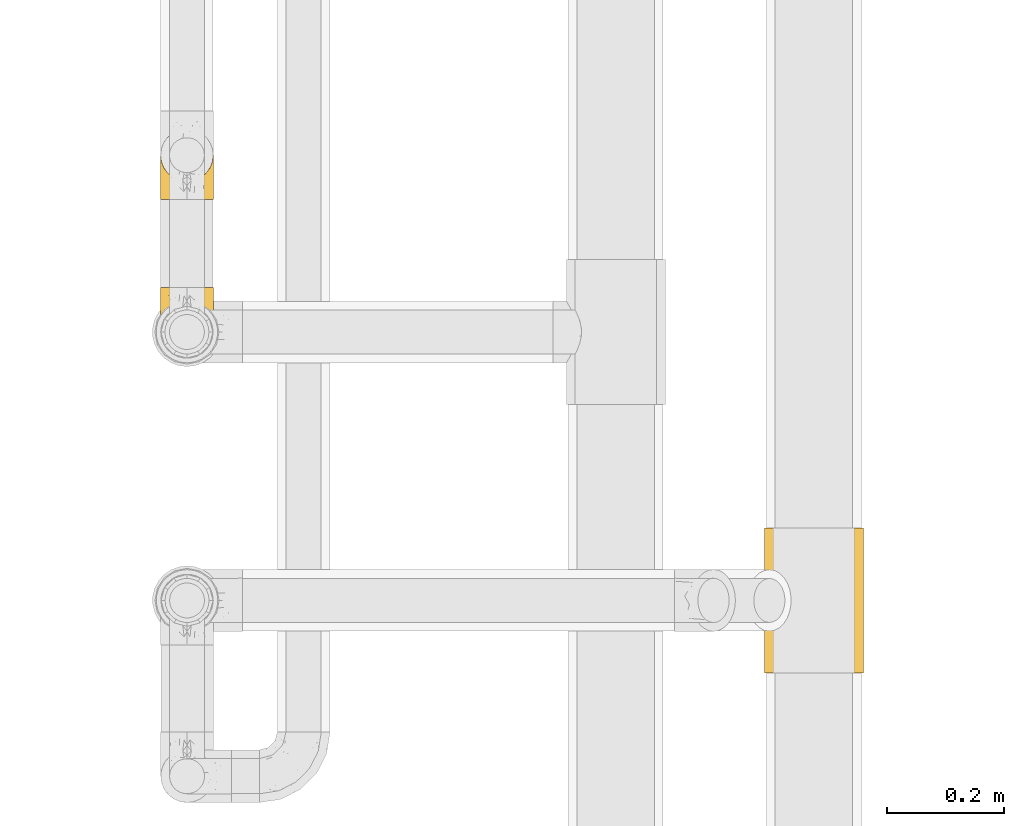
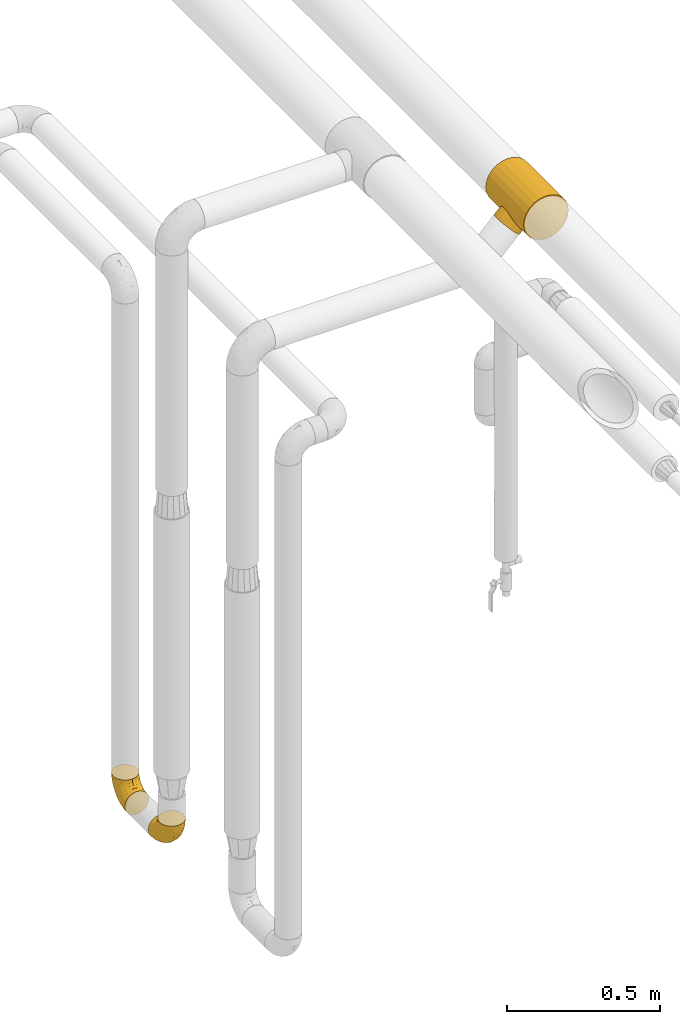
# One storey, part 112 of 827: 3 coverings.
"""IFC2X3 building model written with IfcOpenShell, lengths in millimetres."""

from ifc_helpers import new_model, entity, si_unit, converted_unit, derived_unit, direction, frame, origin, place, context, subcontext, project, spatial, faceted_brep, element, save


model = new_model("IFC2X3")

# Units and contexts
model_context = context("Model", 3, precision=0.01, world=origin(), true_north=direction((6.12303176911189e-17, 1.0)))
body_context = subcontext(model_context, "Body", "Model", "MODEL_VIEW")
ifc_project = project(units=[si_unit("LENGTHUNIT", "METRE", prefix="MILLI"), si_unit("AREAUNIT", "SQUARE_METRE"), si_unit("VOLUMEUNIT", "CUBIC_METRE"), converted_unit("PLANEANGLEUNIT", "DEGREE", entity("IfcRatioMeasure", 0.0174532925199433), si_unit("PLANEANGLEUNIT", "RADIAN"), dimensions=[0, 0, 0, 0, 0, 0, 0]), si_unit("MASSUNIT", "GRAM", prefix="KILO"), derived_unit("MASSDENSITYUNIT", [(si_unit("MASSUNIT", "GRAM", prefix="KILO"), 1), (si_unit("LENGTHUNIT", "METRE"), -3)]), derived_unit("MOMENTOFINERTIAUNIT", [(si_unit("LENGTHUNIT", "METRE"), 4)]), si_unit("TIMEUNIT", "SECOND"), si_unit("FREQUENCYUNIT", "HERTZ"), si_unit("THERMODYNAMICTEMPERATUREUNIT", "DEGREE_CELSIUS"), derived_unit("THERMALTRANSMITTANCEUNIT", [(si_unit("MASSUNIT", "GRAM", prefix="KILO"), 1), (si_unit("THERMODYNAMICTEMPERATUREUNIT", "KELVIN"), -1), (si_unit("TIMEUNIT", "SECOND"), -3)]), derived_unit("VOLUMETRICFLOWRATEUNIT", [(si_unit("LENGTHUNIT", "METRE"), 3), (si_unit("TIMEUNIT", "SECOND"), -1)]), derived_unit("MASSFLOWRATEUNIT", [(si_unit("MASSUNIT", "GRAM", prefix="KILO"), 1), (si_unit("TIMEUNIT", "SECOND"), -1)]), derived_unit("ROTATIONALFREQUENCYUNIT", [(si_unit("TIMEUNIT", "SECOND"), -1)]), si_unit("ELECTRICCURRENTUNIT", "AMPERE"), si_unit("ELECTRICVOLTAGEUNIT", "VOLT"), si_unit("POWERUNIT", "WATT"), si_unit("FORCEUNIT", "NEWTON", prefix="KILO"), si_unit("ILLUMINANCEUNIT", "LUX"), si_unit("LUMINOUSFLUXUNIT", "LUMEN"), si_unit("LUMINOUSINTENSITYUNIT", "CANDELA"), derived_unit("USERDEFINED", [(si_unit("MASSUNIT", "GRAM", prefix="KILO"), -1), (si_unit("LENGTHUNIT", "METRE"), -2), (si_unit("TIMEUNIT", "SECOND"), 3), (si_unit("LUMINOUSFLUXUNIT", "LUMEN"), 1)]), derived_unit("LINEARVELOCITYUNIT", [(si_unit("LENGTHUNIT", "METRE"), 1), (si_unit("TIMEUNIT", "SECOND"), -1)]), si_unit("PRESSUREUNIT", "PASCAL"), derived_unit("USERDEFINED", [(si_unit("LENGTHUNIT", "METRE"), -2), (si_unit("MASSUNIT", "GRAM", prefix="KILO"), 1), (si_unit("TIMEUNIT", "SECOND"), -2)]), derived_unit("LINEARFORCEUNIT", [(si_unit("MASSUNIT", "GRAM", prefix="KILO"), 1), (si_unit("LENGTHUNIT", "METRE"), 1), (si_unit("TIMEUNIT", "SECOND"), -2), (si_unit("LENGTHUNIT", "METRE"), -1)]), derived_unit("PLANARFORCEUNIT", [(si_unit("MASSUNIT", "GRAM", prefix="KILO"), 1), (si_unit("LENGTHUNIT", "METRE"), 1), (si_unit("TIMEUNIT", "SECOND"), -2), (si_unit("LENGTHUNIT", "METRE"), -2)])], contexts=[model_context])

# Site, building, storey
site_placement = place(None, origin())
site = spatial("IfcSite", under=ifc_project, at=site_placement, CompositionType="ELEMENT")
building_placement = place(site_placement, origin())
building = spatial("IfcBuilding", under=site, at=building_placement, CompositionType="ELEMENT")
storey_placement = place(building_placement, frame((0.0, 0.0, 28200.0)))
storey = spatial("IfcBuildingStorey", under=building, at=storey_placement, Name="08", CompositionType="ELEMENT", Elevation=28200.0)

# Coverings
covering_1_placement = place(storey_placement, frame((22059.28, 10675.65, 2684.46)))
element("IfcCovering", 1, at=covering_1_placement, inside=storey, Name=":ADSK_", ObjectType=":ADSK_", PredefinedType="INSULATION", context=body_context, shape_type="Brep", body=[
    faceted_brep([(197.43, 0.0, 137.44), (188.96, 0.0, 157.9), (175.47, 0.0, 175.47), (157.9, 0.0, 188.96), (137.44, 0.0, 197.43), (115.47, 0.0, 200.32), (93.51, 0.0, 197.43), (73.05, 0.0, 188.96), (55.48, 0.0, 175.47), (41.99, 0.0, 157.9), (33.52, 0.0, 137.44), (30.62, 0.0, 115.47), (33.52, 0.0, 93.51), (37.75, 0.0, 83.28), (41.99, 0.0, 73.05), (48.73, 0.0, 64.26), (55.48, 0.0, 55.48), (64.26, 0.0, 48.73), (73.05, 0.0, 41.99), (83.28, 0.0, 37.75), (93.51, 0.0, 33.52), (115.47, 0.0, 30.62), (137.44, 0.0, 33.52), (157.9, 0.0, 41.99), (175.47, 0.0, 55.48), (188.96, 0.0, 73.05), (197.43, 0.0, 93.51), (200.32, 0.0, 115.47), (55.48, 248.0, 175.47), (73.05, 248.0, 188.96), (93.51, 248.0, 197.43), (115.47, 248.0, 200.32), (137.44, 248.0, 197.43), (157.9, 248.0, 188.96), (175.47, 248.0, 175.47), (188.96, 248.0, 157.9), (197.43, 248.0, 137.44), (200.32, 248.0, 115.47), (197.43, 248.0, 93.51), (188.96, 248.0, 73.05), (175.47, 248.0, 55.48), (157.9, 248.0, 41.99), (137.44, 248.0, 33.52), (115.47, 248.0, 30.62), (93.51, 248.0, 33.52), (83.28, 248.0, 37.75), (73.05, 248.0, 41.99), (64.26, 248.0, 48.73), (55.48, 248.0, 55.48), (48.73, 248.0, 64.26), (41.99, 248.0, 73.05), (37.75, 248.0, 83.28), (33.52, 248.0, 93.51), (30.62, 248.0, 115.47), (33.52, 248.0, 137.44), (41.99, 248.0, 157.9), (32.13, 147.29, 99.54), (41.25, 76.39, 74.36), (36.75, 82.7, 83.83), (31.35, 136.08, 104.4), (47.52, 175.65, 64.66), (31.14, 124.0, 106.16), (31.35, 111.92, 104.4), (55.48, 70.95, 55.48), (47.52, 72.35, 64.66), (32.13, 100.71, 99.54), (36.75, 165.3, 83.83), (33.81, 157.11, 92.43), (41.25, 171.61, 74.36), (55.48, 177.05, 55.48), (33.81, 90.89, 92.43), (64.66, 175.65, 47.52), (74.36, 171.61, 41.25), (92.43, 157.11, 33.81), (83.83, 165.3, 36.75), (64.66, 72.35, 47.52), (74.36, 76.39, 41.25), (83.83, 82.7, 36.75), (92.43, 90.89, 33.81), (99.54, 147.29, 32.13), (104.4, 136.08, 31.35), (106.16, 124.0, 31.14), (99.54, 100.71, 32.13), (104.4, 111.92, 31.35), (1.6, 124.0, 76.62), (2.87, 137.73, 75.34), (6.62, 150.52, 71.59), (12.58, 161.51, 65.63), (20.35, 169.94, 57.86), (29.4, 175.24, 48.82), (39.11, 177.05, 39.11), (48.82, 175.24, 29.4), (57.86, 169.94, 20.35), (65.63, 161.51, 12.58), (71.59, 150.52, 6.62), (75.34, 137.73, 2.87), (76.62, 124.0, 1.6), (75.34, 110.27, 2.87), (71.59, 97.47, 6.62), (65.63, 86.49, 12.58), (57.86, 78.06, 20.35), (48.82, 72.76, 29.4), (39.11, 70.95, 39.11), (29.4, 72.76, 48.82), (20.35, 78.06, 57.86), (12.58, 86.49, 65.63), (6.62, 97.47, 71.59), (2.87, 110.27, 75.34)], [[[0, 1, 2, 3, 4, 5, 6, 7, 8, 9, 10, 11, 12, 13, 14, 15, 16, 17, 18, 19, 20, 21, 22, 23, 24, 25, 26, 27]], [[28, 29, 30, 31, 32, 33, 34, 35, 36, 37, 38, 39, 40, 41, 42, 43, 44, 45, 46, 47, 48, 49, 50, 51, 52, 53, 54, 55]], [[3, 33, 32, 4]], [[4, 32, 31, 5]], [[34, 33, 3, 2]], [[6, 30, 29, 7]], [[7, 29, 28, 8]], [[5, 31, 30, 6]], [[55, 9, 8, 28]], [[54, 10, 9, 55]], [[53, 52, 56]], [[57, 13, 58]], [[56, 59, 53]], [[60, 50, 49]], [[54, 53, 11, 10]], [[53, 59, 61]], [[61, 62, 11]], [[63, 15, 64]], [[11, 65, 12]], [[65, 11, 62]], [[66, 52, 51]], [[11, 53, 61]], [[56, 52, 67]], [[67, 52, 66]], [[66, 51, 68]], [[48, 69, 49]], [[63, 16, 15]], [[60, 49, 69]], [[50, 60, 68]], [[50, 68, 51]], [[70, 58, 12]], [[13, 57, 14]], [[58, 13, 12]], [[12, 65, 70]], [[15, 14, 64]], [[64, 14, 57]], [[48, 47, 69]], [[63, 17, 16]], [[71, 47, 46]], [[46, 72, 71]], [[46, 45, 72]], [[44, 73, 74]], [[74, 45, 44]], [[75, 17, 63]], [[76, 19, 18]], [[76, 77, 19]], [[76, 18, 75]], [[77, 78, 20]], [[79, 43, 80]], [[43, 79, 44]], [[69, 47, 71]], [[72, 45, 74]], [[42, 41, 23, 22]], [[21, 43, 42, 22]], [[80, 43, 81]], [[23, 41, 40, 24]], [[21, 82, 83]], [[75, 18, 17]], [[21, 20, 82]], [[20, 78, 82]], [[83, 81, 21]], [[77, 20, 19]], [[81, 43, 21]], [[79, 73, 44]], [[25, 39, 38, 26]], [[26, 38, 37, 27]], [[40, 39, 25, 24]], [[0, 36, 35, 1]], [[1, 35, 34, 2]], [[27, 37, 36, 0]], [[84, 85, 86, 87, 88, 89, 90, 91, 92, 93, 94, 95, 96, 97, 98, 99, 100, 101, 102, 103, 104, 105, 106, 107]], [[60, 90, 89]], [[68, 89, 88]], [[60, 69, 90]], [[66, 68, 88]], [[60, 89, 68]], [[88, 87, 66]], [[67, 87, 86]], [[56, 86, 85]], [[59, 85, 84]], [[67, 86, 56]], [[59, 56, 85]], [[61, 59, 84]], [[87, 67, 66]], [[62, 84, 107]], [[65, 107, 106]], [[61, 84, 62]], [[62, 107, 65]], [[106, 70, 65]], [[106, 105, 70]], [[105, 104, 58]], [[104, 103, 57]], [[64, 103, 102]], [[57, 58, 104]], [[63, 64, 102]], [[57, 103, 64]], [[105, 58, 70]], [[75, 102, 101]], [[76, 101, 100]], [[75, 63, 102]], [[77, 76, 100]], [[75, 101, 76]], [[100, 99, 77]], [[99, 98, 78]], [[98, 97, 82]], [[83, 97, 96]], [[78, 98, 82]], [[83, 82, 97]], [[81, 83, 96]], [[99, 78, 77]], [[80, 96, 95]], [[79, 95, 94]], [[81, 96, 80]], [[80, 95, 79]], [[94, 73, 79]], [[94, 93, 73]], [[93, 92, 74]], [[92, 91, 72]], [[71, 91, 90]], [[72, 74, 92]], [[69, 71, 90]], [[72, 91, 71]], [[93, 74, 73]]]),
])
covering_2_placement = place(storey_placement, frame((21053.31, 11485.27, 303.26)))
element("IfcCovering", 2, at=covering_2_placement, inside=storey, Name=":ADSK_", ObjectType=":ADSK_", PredefinedType="INSULATION", context=body_context, shape_type="Brep", body=[
    faceted_brep([(2.73, 1.6, 36.69), (6.07, 1.6, 27.15), (11.45, 1.6, 18.59), (18.6, 1.6, 11.44), (27.16, 1.6, 6.06), (36.7, 1.6, 2.73), (46.75, 1.6, 1.6), (56.8, 1.6, 2.73), (66.34, 1.6, 6.07), (74.9, 1.6, 11.45), (82.05, 1.6, 18.6), (87.43, 1.6, 27.16), (90.76, 1.6, 36.7), (91.9, 1.6, 46.75), (90.76, 1.6, 56.8), (87.42, 1.6, 66.34), (82.04, 1.6, 74.9), (74.89, 1.6, 82.05), (66.33, 1.6, 87.43), (56.79, 1.6, 90.76), (46.75, 1.6, 91.9), (36.69, 1.6, 90.76), (27.15, 1.6, 87.42), (18.59, 1.6, 82.04), (11.44, 1.6, 74.89), (6.06, 1.6, 66.33), (2.73, 1.6, 56.79), (1.6, 1.6, 46.75), (58.43, 33.98, 122.75), (69.32, 38.49, 122.75), (78.67, 45.67, 122.75), (85.85, 55.02, 122.75), (90.36, 65.91, 122.75), (91.9, 77.6, 122.75), (90.36, 89.28, 122.75), (85.85, 100.17, 122.75), (78.67, 109.52, 122.75), (69.32, 116.7, 122.75), (58.43, 121.21, 122.75), (46.75, 122.75, 122.75), (35.06, 121.21, 122.75), (24.17, 116.7, 122.75), (14.82, 109.52, 122.75), (7.64, 100.17, 122.75), (3.13, 89.28, 122.75), (1.6, 77.6, 122.75), (3.13, 65.91, 122.75), (7.64, 55.02, 122.75), (14.82, 45.67, 122.75), (24.17, 38.49, 122.75), (35.06, 33.98, 122.75), (46.75, 32.45, 122.75), (46.75, 72.81, 24.73), (38.29, 77.17, 29.08), (46.75, 86.21, 38.13), (46.75, 116.82, 85.31), (38.96, 118.49, 93.59), (46.75, 119.23, 100.54), (33.86, 105.14, 63.54), (31.42, 85.37, 38.98), (21.63, 89.33, 50.71), (30.84, 116.14, 93.33), (22.16, 105.06, 75.2), (20.56, 112.15, 100.46), (2.29, 22.95, 41.6), (7.18, 89.91, 80.86), (12.6, 103.39, 94.87), (14.0, 93.6, 67.96), (2.81, 51.41, 52.16), (6.65, 67.71, 52.1), (6.11, 43.53, 36.74), (16.62, 30.91, 17.11), (9.76, 23.58, 23.24), (12.46, 50.07, 29.18), (1.6, 30.68, 52.53), (1.6, 43.01, 60.77), (1.6, 55.34, 69.01), (2.46, 83.48, 100.68), (5.91, 94.96, 103.79), (36.97, 57.29, 16.37), (46.75, 39.03, 7.52), (33.09, 30.66, 7.31), (1.6, 71.81, 93.66), (1.6, 73.63, 102.83), (1.6, 75.46, 112.01), (25.62, 51.57, 18.17), (3.14, 73.13, 71.97), (23.92, 23.16, 9.83), (46.75, 23.8, 5.11), (13.58, 75.6, 45.97), (1.6, 12.33, 48.88), (1.6, 21.51, 50.71), (18.5, 50.46, 22.83), (46.75, 99.61, 51.54), (1.6, 63.57, 81.33), (4.96, 21.26, 31.74), (20.84, 69.54, 32.48), (46.75, 108.21, 68.42), (30.52, 68.42, 25.33), (46.75, 55.92, 16.13), (27.29, 19.36, 92.29), (36.89, 15.76, 94.12), (33.6, 26.13, 100.97), (2.54, 62.78, 95.91), (3.27, 63.65, 107.9), (16.85, 24.34, 87.24), (21.91, 28.46, 95.46), (13.5, 33.53, 90.41), (3.96, 39.46, 74.17), (3.52, 51.05, 83.77), (12.17, 10.94, 76.72), (18.93, 14.55, 84.44), (9.34, 22.21, 76.42), (3.12, 57.05, 90.07), (5.67, 54.0, 99.69), (2.51, 29.19, 61.74), (2.53, 18.85, 58.16), (8.35, 52.84, 112.6), (35.39, 31.47, 110.45), (46.75, 28.31, 107.32), (15.1, 43.0, 108.48), (5.27, 16.9, 66.63), (27.43, 35.98, 115.23), (24.89, 33.91, 105.79), (29.71, 9.97, 89.6), (5.07, 25.93, 69.39), (2.88, 35.61, 66.99), (9.69, 47.45, 102.31), (15.51, 38.26, 99.54), (2.27, 11.7, 55.27), (10.03, 30.13, 82.03), (46.75, 12.12, 94.71), (46.75, 17.02, 96.03), (8.83, 44.39, 94.11), (7.16, 39.83, 84.21), (46.75, 22.67, 101.67), (46.75, 29.63, 112.22), (78.39, 43.0, 108.48), (83.8, 47.45, 102.31), (77.97, 38.26, 99.54), (84.66, 44.38, 94.11), (58.1, 31.47, 110.46), (81.31, 10.93, 76.74), (91.9, 21.51, 50.71), (90.96, 18.84, 58.17), (91.22, 11.7, 55.27), (56.59, 15.76, 94.12), (66.18, 19.36, 92.3), (59.87, 26.14, 100.98), (88.42, 25.94, 69.41), (84.13, 22.21, 76.44), (88.22, 16.9, 66.65), (66.06, 35.98, 115.24), (91.9, 73.63, 102.83), (91.9, 75.46, 112.01), (83.44, 30.12, 82.05), (76.62, 24.33, 87.25), (85.14, 52.84, 112.6), (90.22, 63.65, 107.9), (91.9, 71.81, 93.66), (71.55, 28.45, 95.48), (63.77, 9.97, 89.6), (91.9, 43.01, 60.77), (91.9, 55.34, 69.01), (89.53, 39.46, 74.17), (91.9, 12.33, 48.88), (74.55, 14.54, 84.45), (90.95, 62.78, 95.91), (90.37, 57.05, 90.07), (91.9, 63.57, 81.33), (90.98, 29.2, 61.75), (89.97, 51.05, 83.77), (86.32, 39.81, 84.21), (91.9, 30.68, 52.53), (79.97, 33.52, 90.42), (90.61, 35.61, 67.0), (87.82, 54.0, 99.69), (68.6, 33.91, 105.8), (80.89, 103.39, 94.87), (86.31, 89.91, 80.86), (79.49, 93.6, 67.95), (71.33, 105.05, 75.17), (71.88, 89.27, 50.65), (90.35, 73.13, 71.97), (86.85, 67.67, 52.08), (72.67, 69.49, 32.46), (62.08, 85.36, 38.98), (87.58, 94.96, 103.79), (91.03, 83.48, 100.68), (59.62, 105.14, 63.54), (62.65, 116.13, 93.32), (54.53, 118.49, 93.59), (72.93, 112.15, 100.44), (90.68, 51.41, 52.17), (87.39, 43.51, 36.75), (91.2, 22.95, 41.61), (60.41, 30.66, 7.31), (76.88, 30.91, 17.12), (56.53, 57.3, 16.37), (83.74, 23.58, 23.26), (67.88, 51.56, 18.17), (62.99, 68.41, 25.33), (69.58, 23.16, 9.84), (81.04, 50.07, 29.19), (75.0, 50.45, 22.84), (88.53, 21.25, 31.75), (79.93, 75.56, 45.96), (55.21, 77.16, 29.07)], [[[0, 1, 2, 3, 4, 5, 6, 7, 8, 9, 10, 11, 12, 13, 14, 15, 16, 17, 18, 19, 20, 21, 22, 23, 24, 25, 26, 27]], [[28, 29, 30, 31, 32, 33, 34, 35, 36, 37, 38, 39, 40, 41, 42, 43, 44, 45, 46, 47, 48, 49, 50, 51]], [[52, 53, 54]], [[55, 56, 57]], [[58, 59, 60]], [[61, 62, 63]], [[27, 64, 0]], [[65, 66, 67]], [[41, 40, 61]], [[68, 69, 70]], [[66, 43, 42]], [[63, 42, 41]], [[71, 72, 73]], [[72, 2, 1]], [[68, 74, 75, 76]], [[45, 44, 77]], [[43, 78, 44]], [[79, 80, 81]], [[77, 82, 83, 84, 45]], [[79, 81, 85]], [[71, 2, 72]], [[65, 86, 77]], [[4, 81, 5]], [[66, 65, 78]], [[4, 3, 87]], [[81, 88, 5]], [[63, 66, 42]], [[68, 70, 64]], [[67, 60, 89]], [[71, 3, 2]], [[64, 27, 90, 91, 74]], [[92, 71, 73]], [[40, 57, 56]], [[59, 93, 54]], [[86, 76, 94, 82]], [[1, 0, 95]], [[58, 62, 61]], [[60, 96, 89]], [[85, 81, 87]], [[56, 97, 58]], [[65, 67, 69]], [[87, 81, 4]], [[67, 89, 69]], [[61, 63, 41]], [[95, 72, 1]], [[73, 72, 70]], [[69, 73, 70]], [[73, 89, 96]], [[3, 71, 87]], [[85, 87, 71]], [[58, 61, 56]], [[59, 58, 93]], [[76, 86, 68]], [[69, 89, 73]], [[68, 86, 69]], [[65, 69, 86]], [[68, 64, 74]], [[95, 64, 70]], [[98, 79, 85]], [[79, 52, 99, 80]], [[66, 62, 67]], [[62, 58, 60]], [[62, 60, 67]], [[59, 98, 96]], [[59, 96, 60]], [[96, 85, 92]], [[88, 81, 80]], [[88, 6, 5]], [[66, 63, 62]], [[64, 95, 0]], [[72, 95, 70]], [[77, 44, 78]], [[86, 82, 77]], [[40, 39, 57]], [[96, 98, 85]], [[40, 56, 61]], [[66, 78, 43]], [[77, 78, 65]], [[79, 98, 53]], [[96, 92, 73]], [[85, 71, 92]], [[97, 56, 55]], [[97, 93, 58]], [[53, 98, 59]], [[54, 53, 59]], [[79, 53, 52]], [[100, 101, 102]], [[46, 45, 84, 83]], [[103, 104, 82]], [[82, 104, 83]], [[105, 106, 107]], [[108, 109, 76]], [[110, 111, 112]], [[103, 113, 114]], [[115, 74, 116]], [[48, 47, 117]], [[118, 102, 119]], [[49, 48, 120]], [[74, 91, 116]], [[116, 121, 115]], [[49, 122, 50]], [[123, 106, 102]], [[124, 111, 22]], [[125, 126, 115]], [[23, 22, 111]], [[24, 110, 121]], [[120, 127, 128]], [[90, 26, 129]], [[27, 26, 90]], [[121, 125, 115]], [[24, 121, 25]], [[130, 105, 107]], [[129, 25, 116]], [[21, 20, 131]], [[120, 123, 122]], [[112, 105, 130]], [[50, 118, 51]], [[21, 124, 22]], [[101, 131, 132]], [[117, 120, 48]], [[24, 23, 110]], [[127, 114, 133]], [[75, 108, 76]], [[107, 134, 130]], [[133, 114, 113]], [[129, 116, 91]], [[25, 121, 116]], [[121, 112, 125]], [[75, 74, 115]], [[101, 135, 102]], [[131, 101, 21]], [[101, 100, 124]], [[128, 127, 133]], [[119, 136, 51, 118]], [[104, 47, 46]], [[83, 104, 46]], [[117, 104, 114]], [[101, 124, 21]], [[111, 124, 100]], [[102, 118, 123]], [[133, 134, 107]], [[111, 110, 23]], [[114, 104, 103]], [[94, 76, 109]], [[121, 110, 112]], [[122, 118, 50]], [[134, 109, 108]], [[133, 107, 128]], [[112, 108, 125]], [[126, 125, 108]], [[108, 75, 126]], [[75, 115, 126]], [[109, 134, 133]], [[130, 108, 112]], [[108, 130, 134]], [[105, 112, 111]], [[111, 100, 105]], [[106, 105, 100]], [[102, 106, 100]], [[128, 106, 123]], [[90, 129, 91]], [[25, 129, 26]], [[104, 117, 47]], [[117, 114, 127]], [[82, 94, 103]], [[113, 94, 109]], [[94, 113, 103]], [[133, 113, 109]], [[106, 128, 107]], [[123, 120, 128]], [[120, 122, 49]], [[118, 122, 123]], [[135, 101, 132]], [[135, 119, 102]], [[117, 127, 120]], [[30, 29, 137]], [[138, 139, 140]], [[51, 136, 119, 141]], [[142, 17, 16]], [[143, 144, 145]], [[146, 147, 148]], [[149, 150, 151]], [[152, 29, 28]], [[33, 32, 153, 154]], [[150, 155, 156]], [[157, 31, 30]], [[153, 158, 159]], [[29, 152, 137]], [[148, 141, 119]], [[156, 160, 147]], [[148, 135, 146]], [[137, 138, 157]], [[19, 161, 146]], [[162, 163, 164]], [[14, 13, 165]], [[153, 32, 158]], [[147, 161, 166]], [[18, 17, 166]], [[167, 168, 169]], [[166, 150, 156]], [[151, 150, 142]], [[151, 170, 149]], [[151, 16, 15]], [[171, 140, 172]], [[165, 143, 145]], [[173, 170, 144]], [[142, 166, 17]], [[19, 131, 20]], [[144, 170, 151]], [[18, 161, 19]], [[173, 144, 143]], [[140, 139, 174]], [[171, 164, 163]], [[164, 172, 155]], [[151, 15, 144]], [[145, 15, 14]], [[173, 162, 170]], [[149, 175, 164]], [[19, 146, 131]], [[132, 131, 146]], [[160, 148, 147]], [[159, 158, 167]], [[135, 132, 146]], [[158, 32, 31]], [[157, 158, 31]], [[167, 158, 176]], [[166, 161, 18]], [[146, 161, 147]], [[148, 177, 141]], [[171, 168, 140]], [[171, 163, 169]], [[151, 142, 16]], [[166, 142, 150]], [[152, 141, 177]], [[51, 141, 28]], [[138, 140, 176]], [[172, 140, 174]], [[175, 149, 170]], [[164, 150, 149]], [[170, 162, 175]], [[162, 164, 175]], [[155, 172, 174]], [[171, 172, 164]], [[155, 174, 156]], [[164, 155, 150]], [[160, 156, 174]], [[147, 166, 156]], [[139, 160, 174]], [[148, 160, 177]], [[15, 145, 144]], [[165, 145, 14]], [[137, 157, 30]], [[158, 157, 176]], [[168, 167, 176]], [[169, 159, 167]], [[140, 168, 176]], [[169, 168, 171]], [[137, 177, 139]], [[160, 139, 177]], [[141, 152, 28]], [[137, 152, 177]], [[148, 119, 135]], [[157, 138, 176]], [[139, 138, 137]], [[178, 179, 180]], [[181, 180, 182]], [[179, 183, 184]], [[185, 186, 182]], [[187, 188, 179]], [[188, 33, 154, 153, 159]], [[181, 189, 190]], [[35, 34, 187]], [[191, 38, 190]], [[192, 178, 181]], [[179, 184, 180]], [[192, 190, 37]], [[37, 190, 38]], [[36, 35, 178]], [[54, 93, 186]], [[35, 187, 178]], [[193, 194, 184]], [[195, 173, 143, 165, 13]], [[195, 193, 173]], [[193, 163, 162, 173]], [[13, 12, 195]], [[8, 7, 196]], [[9, 197, 10]], [[198, 80, 99, 52]], [[196, 7, 88]], [[197, 199, 10]], [[182, 189, 181]], [[200, 198, 201]], [[200, 196, 198]], [[9, 8, 202]], [[194, 199, 203]], [[192, 37, 36]], [[80, 196, 88]], [[183, 159, 169, 163]], [[188, 34, 33]], [[202, 200, 197]], [[185, 203, 204]], [[202, 8, 196]], [[10, 199, 11]], [[12, 11, 205]], [[38, 191, 57]], [[189, 97, 191]], [[203, 199, 197]], [[205, 199, 194]], [[204, 203, 197]], [[184, 203, 206]], [[200, 202, 196]], [[197, 9, 202]], [[207, 54, 186]], [[97, 55, 191]], [[194, 203, 184]], [[183, 163, 193]], [[184, 206, 180]], [[183, 193, 184]], [[205, 195, 12]], [[193, 195, 194]], [[80, 198, 196]], [[207, 186, 201]], [[182, 180, 206]], [[181, 178, 180]], [[185, 182, 206]], [[182, 186, 189]], [[203, 185, 206]], [[185, 200, 201]], [[7, 6, 88]], [[178, 192, 36]], [[190, 192, 181]], [[199, 205, 11]], [[195, 205, 194]], [[159, 183, 188]], [[179, 188, 183]], [[57, 191, 55]], [[57, 39, 38]], [[189, 191, 190]], [[188, 187, 34]], [[178, 187, 179]], [[186, 93, 189]], [[197, 200, 204]], [[185, 204, 200]], [[189, 93, 97]], [[207, 198, 52]], [[185, 201, 186]], [[198, 207, 201]], [[54, 207, 52]]]),
])
covering_3_placement = place(storey_placement, frame((21053.31, 11212.9, 303.26)))
element("IfcCovering", 3, at=covering_3_placement, inside=storey, Name=":ADSK_", ObjectType=":ADSK_", PredefinedType="INSULATION", context=body_context, shape_type="Brep", body=[
    faceted_brep([(2.73, 36.69, 122.75), (6.07, 27.15, 122.75), (11.45, 18.59, 122.75), (18.6, 11.44, 122.75), (27.16, 6.06, 122.75), (36.7, 2.73, 122.75), (46.75, 1.6, 122.75), (56.8, 2.73, 122.75), (66.34, 6.07, 122.75), (74.9, 11.45, 122.75), (82.05, 18.6, 122.75), (87.43, 27.16, 122.75), (90.76, 36.7, 122.75), (91.9, 46.75, 122.75), (90.76, 56.8, 122.75), (87.42, 66.34, 122.75), (82.04, 74.9, 122.75), (74.89, 82.05, 122.75), (66.33, 87.43, 122.75), (56.79, 90.76, 122.75), (46.75, 91.9, 122.75), (36.69, 90.76, 122.75), (27.15, 87.42, 122.75), (18.59, 82.04, 122.75), (11.44, 74.89, 122.75), (6.06, 66.33, 122.75), (2.73, 56.79, 122.75), (1.6, 46.75, 122.75), (58.43, 122.75, 90.36), (69.32, 122.75, 85.85), (78.67, 122.75, 78.67), (85.85, 122.75, 69.32), (90.36, 122.75, 58.43), (91.9, 122.75, 46.75), (90.36, 122.75, 35.06), (85.85, 122.75, 24.17), (78.67, 122.75, 14.82), (69.32, 122.75, 7.64), (58.43, 122.75, 3.13), (46.75, 122.75, 1.6), (35.06, 122.75, 3.13), (24.17, 122.75, 7.64), (14.82, 122.75, 14.82), (7.64, 122.75, 24.17), (3.13, 122.75, 35.06), (1.6, 122.75, 46.75), (3.13, 122.75, 58.43), (7.64, 122.75, 69.32), (14.82, 122.75, 78.67), (24.17, 122.75, 85.85), (35.06, 122.75, 90.36), (46.75, 122.75, 91.9), (46.75, 24.73, 51.54), (38.29, 29.08, 47.17), (46.75, 38.13, 38.13), (46.75, 85.31, 7.52), (38.96, 93.59, 5.85), (46.75, 100.54, 5.11), (33.86, 63.54, 19.2), (31.42, 38.98, 38.98), (21.63, 50.71, 35.02), (30.84, 93.33, 8.21), (22.16, 75.2, 19.28), (20.56, 100.46, 12.19), (2.29, 41.6, 101.39), (7.18, 80.86, 34.43), (12.6, 94.87, 20.95), (14.0, 67.96, 30.74), (2.81, 52.16, 72.93), (6.65, 52.1, 56.64), (6.11, 36.74, 80.81), (16.62, 17.11, 93.43), (9.76, 23.24, 100.76), (12.46, 29.18, 74.27), (1.6, 52.53, 93.66), (1.6, 60.77, 81.33), (1.6, 69.01, 69.01), (2.46, 100.68, 40.87), (5.91, 103.79, 29.38), (36.97, 16.37, 67.05), (46.75, 7.52, 85.31), (33.09, 7.31, 93.68), (1.6, 93.66, 52.53), (1.6, 102.83, 50.71), (1.6, 112.01, 48.88), (25.62, 18.17, 72.77), (3.14, 71.97, 51.21), (23.92, 9.83, 101.18), (46.75, 5.11, 100.54), (13.58, 45.97, 48.74), (1.6, 48.88, 112.01), (1.6, 50.71, 102.83), (18.5, 22.83, 73.88), (46.75, 51.54, 24.73), (1.6, 81.33, 60.77), (4.96, 31.74, 103.08), (20.84, 32.48, 54.8), (46.75, 68.42, 16.13), (30.52, 25.33, 55.92), (46.75, 16.13, 68.42), (27.29, 92.29, 104.98), (36.89, 94.12, 108.58), (33.6, 100.97, 98.21), (2.54, 95.91, 61.56), (3.27, 107.9, 60.69), (16.85, 87.24, 100.0), (21.91, 95.46, 95.88), (13.5, 90.41, 90.81), (3.96, 74.17, 84.88), (3.52, 83.77, 73.29), (12.17, 76.72, 113.4), (18.93, 84.44, 109.8), (9.34, 76.42, 102.13), (3.12, 90.07, 67.29), (5.67, 99.69, 70.34), (2.51, 61.74, 95.15), (2.53, 58.16, 105.49), (8.35, 112.6, 71.5), (35.39, 110.45, 92.87), (46.75, 107.32, 96.03), (15.1, 108.48, 81.34), (5.27, 66.63, 107.44), (27.43, 115.23, 88.36), (24.89, 105.79, 90.43), (29.71, 89.6, 114.37), (5.07, 69.39, 98.41), (2.88, 66.99, 88.73), (9.69, 102.31, 76.89), (15.51, 99.54, 86.08), (2.27, 55.27, 112.64), (10.03, 82.03, 94.21), (46.75, 94.71, 112.22), (46.75, 96.03, 107.32), (8.83, 94.11, 79.95), (7.16, 84.21, 84.51), (46.75, 101.67, 101.67), (46.75, 112.22, 94.71), (78.39, 108.48, 81.34), (83.8, 102.31, 76.89), (77.97, 99.54, 86.08), (84.66, 94.11, 79.96), (58.1, 110.46, 92.87), (81.31, 76.74, 113.41), (91.9, 50.71, 102.83), (90.96, 58.17, 105.5), (91.22, 55.27, 112.64), (56.59, 94.12, 108.58), (66.18, 92.3, 104.98), (59.87, 100.98, 98.2), (88.42, 69.41, 98.4), (84.13, 76.44, 102.13), (88.22, 66.65, 107.44), (66.06, 115.24, 88.36), (91.9, 102.83, 50.71), (91.9, 112.01, 48.88), (83.44, 82.05, 94.22), (76.62, 87.25, 100.01), (85.14, 112.6, 71.5), (90.22, 107.9, 60.69), (91.9, 93.66, 52.53), (71.55, 95.48, 95.89), (63.77, 89.6, 114.37), (91.9, 60.77, 81.33), (91.9, 69.01, 69.01), (89.53, 74.17, 84.88), (91.9, 48.88, 112.01), (74.55, 84.45, 109.8), (90.95, 95.91, 61.56), (90.37, 90.07, 67.29), (91.9, 81.33, 60.77), (90.98, 61.75, 95.14), (89.97, 83.77, 73.29), (86.32, 84.21, 84.53), (91.9, 52.53, 93.66), (79.97, 90.42, 90.82), (90.61, 67.0, 88.73), (87.82, 99.69, 70.34), (68.6, 105.8, 90.43), (80.89, 94.87, 20.95), (86.31, 80.86, 34.43), (79.49, 67.95, 30.74), (71.33, 75.17, 19.29), (71.88, 50.65, 35.07), (90.35, 71.97, 51.21), (86.85, 52.08, 56.67), (72.67, 32.46, 54.85), (62.08, 38.98, 38.98), (87.58, 103.79, 29.38), (91.03, 100.68, 40.87), (59.62, 63.54, 19.2), (62.65, 93.32, 8.21), (54.53, 93.59, 5.85), (72.93, 100.44, 12.19), (90.68, 52.17, 72.93), (87.39, 36.75, 80.83), (91.2, 41.61, 101.39), (60.41, 7.31, 93.69), (76.88, 17.12, 93.43), (56.53, 16.37, 67.04), (83.74, 23.26, 100.76), (67.88, 18.17, 72.78), (62.99, 25.33, 55.93), (69.58, 9.84, 101.18), (81.04, 29.19, 74.27), (75.0, 22.84, 73.89), (88.53, 31.75, 103.09), (79.93, 45.96, 48.78), (55.21, 29.07, 47.19)], [[[0, 1, 2, 3, 4, 5, 6, 7, 8, 9, 10, 11, 12, 13, 14, 15, 16, 17, 18, 19, 20, 21, 22, 23, 24, 25, 26, 27]], [[28, 29, 30, 31, 32, 33, 34, 35, 36, 37, 38, 39, 40, 41, 42, 43, 44, 45, 46, 47, 48, 49, 50, 51]], [[52, 53, 54]], [[55, 56, 57]], [[58, 59, 60]], [[61, 62, 63]], [[27, 64, 0]], [[65, 66, 67]], [[41, 40, 61]], [[68, 69, 70]], [[66, 43, 42]], [[63, 42, 41]], [[71, 72, 73]], [[72, 2, 1]], [[68, 74, 75, 76]], [[45, 44, 77]], [[43, 78, 44]], [[79, 80, 81]], [[77, 82, 83, 84, 45]], [[79, 81, 85]], [[71, 2, 72]], [[65, 86, 77]], [[4, 81, 5]], [[66, 65, 78]], [[4, 3, 87]], [[81, 88, 5]], [[63, 66, 42]], [[68, 70, 64]], [[67, 60, 89]], [[71, 3, 2]], [[64, 27, 90, 91, 74]], [[92, 71, 73]], [[40, 57, 56]], [[59, 93, 54]], [[86, 76, 94, 82]], [[1, 0, 95]], [[58, 62, 61]], [[60, 96, 89]], [[85, 81, 87]], [[56, 97, 58]], [[65, 67, 69]], [[87, 81, 4]], [[67, 89, 69]], [[61, 63, 41]], [[95, 72, 1]], [[73, 72, 70]], [[69, 73, 70]], [[73, 89, 96]], [[3, 71, 87]], [[85, 87, 71]], [[58, 61, 56]], [[59, 58, 93]], [[76, 86, 68]], [[69, 89, 73]], [[68, 86, 69]], [[65, 69, 86]], [[68, 64, 74]], [[95, 64, 70]], [[98, 79, 85]], [[79, 52, 99, 80]], [[66, 62, 67]], [[62, 58, 60]], [[62, 60, 67]], [[59, 98, 96]], [[59, 96, 60]], [[96, 85, 92]], [[88, 81, 80]], [[88, 6, 5]], [[66, 63, 62]], [[64, 95, 0]], [[72, 95, 70]], [[77, 44, 78]], [[86, 82, 77]], [[40, 39, 57]], [[96, 98, 85]], [[40, 56, 61]], [[66, 78, 43]], [[77, 78, 65]], [[79, 98, 53]], [[96, 92, 73]], [[85, 71, 92]], [[97, 56, 55]], [[97, 93, 58]], [[53, 98, 59]], [[54, 53, 59]], [[79, 53, 52]], [[100, 101, 102]], [[46, 45, 84, 83]], [[103, 104, 82]], [[82, 104, 83]], [[105, 106, 107]], [[108, 109, 76]], [[110, 111, 112]], [[103, 113, 114]], [[115, 74, 116]], [[48, 47, 117]], [[118, 102, 119]], [[49, 48, 120]], [[74, 91, 116]], [[116, 121, 115]], [[49, 122, 50]], [[123, 106, 102]], [[124, 111, 22]], [[125, 126, 115]], [[23, 22, 111]], [[24, 110, 121]], [[120, 127, 128]], [[90, 26, 129]], [[27, 26, 90]], [[121, 125, 115]], [[24, 121, 25]], [[130, 105, 107]], [[129, 25, 116]], [[21, 20, 131]], [[120, 123, 122]], [[112, 105, 130]], [[50, 118, 51]], [[21, 124, 22]], [[101, 131, 132]], [[117, 120, 48]], [[24, 23, 110]], [[127, 114, 133]], [[75, 108, 76]], [[107, 134, 130]], [[133, 114, 113]], [[129, 116, 91]], [[25, 121, 116]], [[121, 112, 125]], [[75, 74, 115]], [[101, 135, 102]], [[131, 101, 21]], [[101, 100, 124]], [[128, 127, 133]], [[119, 136, 51, 118]], [[104, 47, 46]], [[83, 104, 46]], [[117, 104, 114]], [[101, 124, 21]], [[111, 124, 100]], [[102, 118, 123]], [[133, 134, 107]], [[111, 110, 23]], [[114, 104, 103]], [[94, 76, 109]], [[121, 110, 112]], [[122, 118, 50]], [[134, 109, 108]], [[133, 107, 128]], [[112, 108, 125]], [[126, 125, 108]], [[108, 75, 126]], [[75, 115, 126]], [[109, 134, 133]], [[130, 108, 112]], [[108, 130, 134]], [[105, 112, 111]], [[111, 100, 105]], [[106, 105, 100]], [[102, 106, 100]], [[128, 106, 123]], [[90, 129, 91]], [[25, 129, 26]], [[104, 117, 47]], [[117, 114, 127]], [[82, 94, 103]], [[113, 94, 109]], [[94, 113, 103]], [[133, 113, 109]], [[106, 128, 107]], [[123, 120, 128]], [[120, 122, 49]], [[118, 122, 123]], [[135, 101, 132]], [[135, 119, 102]], [[117, 127, 120]], [[30, 29, 137]], [[138, 139, 140]], [[51, 136, 119, 141]], [[142, 17, 16]], [[143, 144, 145]], [[146, 147, 148]], [[149, 150, 151]], [[152, 29, 28]], [[33, 32, 153, 154]], [[150, 155, 156]], [[157, 31, 30]], [[153, 158, 159]], [[29, 152, 137]], [[148, 141, 119]], [[156, 160, 147]], [[148, 135, 146]], [[137, 138, 157]], [[19, 161, 146]], [[162, 163, 164]], [[14, 13, 165]], [[153, 32, 158]], [[147, 161, 166]], [[18, 17, 166]], [[167, 168, 169]], [[166, 150, 156]], [[151, 150, 142]], [[151, 170, 149]], [[151, 16, 15]], [[171, 140, 172]], [[165, 143, 145]], [[173, 170, 144]], [[142, 166, 17]], [[19, 131, 20]], [[144, 170, 151]], [[18, 161, 19]], [[173, 144, 143]], [[140, 139, 174]], [[171, 164, 163]], [[164, 172, 155]], [[151, 15, 144]], [[145, 15, 14]], [[173, 162, 170]], [[149, 175, 164]], [[19, 146, 131]], [[132, 131, 146]], [[160, 148, 147]], [[159, 158, 167]], [[135, 132, 146]], [[158, 32, 31]], [[157, 158, 31]], [[167, 158, 176]], [[166, 161, 18]], [[146, 161, 147]], [[148, 177, 141]], [[171, 168, 140]], [[171, 163, 169]], [[151, 142, 16]], [[166, 142, 150]], [[152, 141, 177]], [[51, 141, 28]], [[138, 140, 176]], [[172, 140, 174]], [[175, 149, 170]], [[164, 150, 149]], [[170, 162, 175]], [[162, 164, 175]], [[155, 172, 174]], [[171, 172, 164]], [[155, 174, 156]], [[164, 155, 150]], [[160, 156, 174]], [[147, 166, 156]], [[139, 160, 174]], [[148, 160, 177]], [[15, 145, 144]], [[165, 145, 14]], [[137, 157, 30]], [[158, 157, 176]], [[168, 167, 176]], [[169, 159, 167]], [[140, 168, 176]], [[169, 168, 171]], [[137, 177, 139]], [[160, 139, 177]], [[141, 152, 28]], [[137, 152, 177]], [[148, 119, 135]], [[157, 138, 176]], [[139, 138, 137]], [[178, 179, 180]], [[181, 180, 182]], [[179, 183, 184]], [[185, 186, 182]], [[187, 188, 179]], [[188, 33, 154, 153, 159]], [[181, 189, 190]], [[35, 34, 187]], [[191, 38, 190]], [[192, 178, 181]], [[179, 184, 180]], [[192, 190, 37]], [[37, 190, 38]], [[36, 35, 178]], [[54, 93, 186]], [[35, 187, 178]], [[193, 194, 184]], [[195, 173, 143, 165, 13]], [[195, 193, 173]], [[193, 163, 162, 173]], [[13, 12, 195]], [[8, 7, 196]], [[9, 197, 10]], [[198, 80, 99, 52]], [[196, 7, 88]], [[197, 199, 10]], [[182, 189, 181]], [[200, 198, 201]], [[200, 196, 198]], [[9, 8, 202]], [[194, 199, 203]], [[192, 37, 36]], [[80, 196, 88]], [[183, 159, 169, 163]], [[188, 34, 33]], [[202, 200, 197]], [[185, 203, 204]], [[202, 8, 196]], [[10, 199, 11]], [[12, 11, 205]], [[38, 191, 57]], [[189, 97, 191]], [[203, 199, 197]], [[205, 199, 194]], [[204, 203, 197]], [[184, 203, 206]], [[200, 202, 196]], [[197, 9, 202]], [[207, 54, 186]], [[97, 55, 191]], [[194, 203, 184]], [[183, 163, 193]], [[184, 206, 180]], [[183, 193, 184]], [[205, 195, 12]], [[193, 195, 194]], [[80, 198, 196]], [[207, 186, 201]], [[182, 180, 206]], [[181, 178, 180]], [[185, 182, 206]], [[182, 186, 189]], [[203, 185, 206]], [[185, 200, 201]], [[7, 6, 88]], [[178, 192, 36]], [[190, 192, 181]], [[199, 205, 11]], [[195, 205, 194]], [[159, 183, 188]], [[179, 188, 183]], [[57, 191, 55]], [[57, 39, 38]], [[189, 191, 190]], [[188, 187, 34]], [[178, 187, 179]], [[186, 93, 189]], [[197, 200, 204]], [[185, 204, 200]], [[189, 93, 97]], [[207, 198, 52]], [[185, 201, 186]], [[198, 207, 201]], [[54, 207, 52]]]),
])

save(model, "model.ifc")
